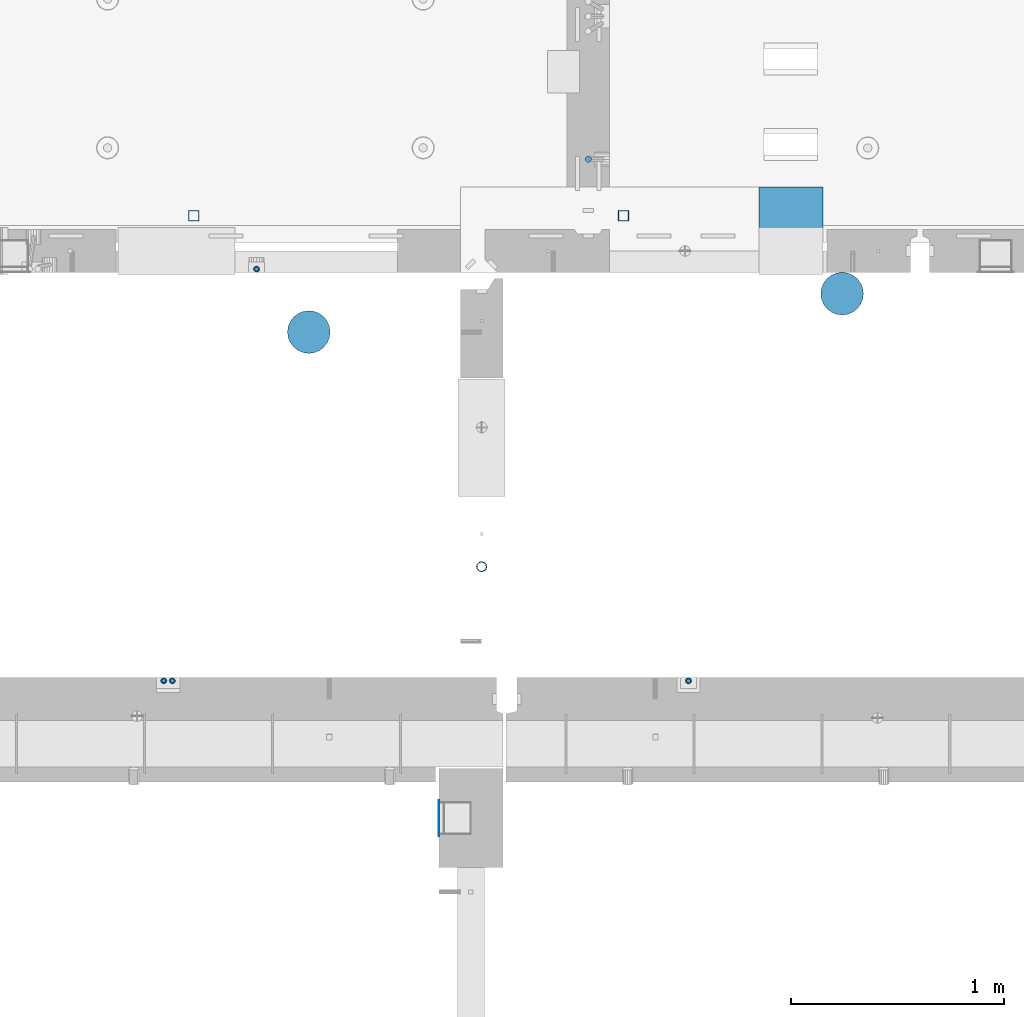
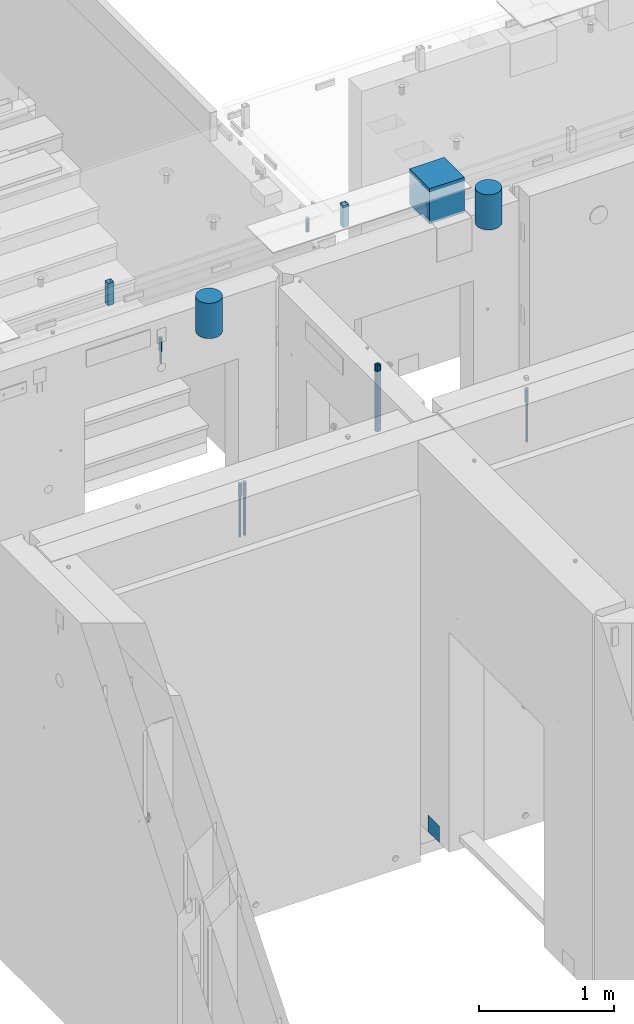
# One storey, part 9 of 264: 16 columns, 14 elements without a shape of their own.
"""IFC2X3 building model written with IfcOpenShell, lengths in millimetres."""

from ifc_helpers import new_model, si_unit, frame, origin_with_axes, place, context, subcontext, project, spatial, faceted_brep, material, type_object, element, aggregate, save


model = new_model("IFC2X3")

# Units and contexts
model_context = context("Model", 3, precision=1e-05, world=origin_with_axes())
body_context = subcontext(model_context, "Body", "Model", "MODEL_VIEW")
ifc_project = project(units=[si_unit("LENGTHUNIT", "METRE", prefix="MILLI"), si_unit("AREAUNIT", "SQUARE_METRE"), si_unit("VOLUMEUNIT", "CUBIC_METRE"), si_unit("MASSUNIT", "GRAM", prefix="KILO"), si_unit("TIMEUNIT", "SECOND"), si_unit("PLANEANGLEUNIT", "RADIAN"), si_unit("SOLIDANGLEUNIT", "STERADIAN"), si_unit("THERMODYNAMICTEMPERATUREUNIT", "DEGREE_CELSIUS"), si_unit("LUMINOUSINTENSITYUNIT", "LUMEN")], contexts=[model_context])

# Site, building, storey
site_placement = place(None, origin_with_axes())
site = spatial("IfcSite", under=ifc_project, at=site_placement, CompositionType="ELEMENT")
building_placement = place(site_placement, origin_with_axes())
building = spatial("IfcBuilding", under=site, at=building_placement, CompositionType="ELEMENT")
storey_placement = place(building_placement, origin_with_axes())
storey = spatial("IfcBuildingStorey", under=building, at=storey_placement, Name="K", CompositionType="ELEMENT", Elevation=0.0)

# Assembly, column
assembly_1_placement = place(storey_placement, origin_with_axes())
assembly_1 = element("IfcElementAssembly", 1, at=assembly_1_placement, inside=storey, AssemblyPlace="NOTDEFINED", PredefinedType="REINFORCEMENT_UNIT")
ifc_material_1 = material()
column_type_1 = type_object("IfcColumnType", Name="D30", PredefinedType="NOTDEFINED")
column_1_placement = place(assembly_1_placement, frame((22310.0, 15610.002446039, 81395.0), z_axis=(-1.0, 3.00000001838171e-08, 0.0), x_axis=(0.0, 0.0, 1.0)))
column_1 = element("IfcColumn", 2, at=column_1_placement, type_object=column_type_1, material=ifc_material_1, ObjectType="D30", context=body_context, shape_type="Brep", body=[
    faceted_brep([(0.0, -15.0, 0.0), (0.0, -12.9903810567666, -7.5), (125.0, -12.9903810567666, -7.5), (125.0, -15.0, 0.0), (0.0, -7.5, -12.9903810567666), (125.0, -7.5, -12.9903810567666), (0.0, 0.0, -15.0), (125.0, 0.0, -15.0), (0.0, 7.5, -12.9903810567666), (125.0, 7.5, -12.9903810567666), (0.0, 12.9903810567666, -7.5), (125.0, 12.9903810567666, -7.5), (0.0, 15.0, 0.0), (125.0, 15.0, 0.0), (0.0, 12.9903810567666, 7.5), (125.0, 12.9903810567666, 7.5), (0.0, 7.5, 12.9903810567666), (125.0, 7.5, 12.9903810567666), (0.0, 0.0, 15.0), (125.0, 0.0, 15.0), (0.0, -7.5, 12.9903810567666), (125.0, -7.5, 12.9903810567666), (0.0, -12.9903810567666, 7.5), (125.0, -12.9903810567666, 7.5)], [[[0, 1, 2, 3]], [[1, 4, 5, 2]], [[4, 6, 7, 5]], [[6, 8, 9, 7]], [[8, 10, 11, 9]], [[10, 12, 13, 11]], [[12, 14, 15, 13]], [[14, 16, 17, 15]], [[16, 18, 19, 17]], [[18, 20, 21, 19]], [[20, 22, 23, 21]], [[22, 0, 3, 23]], [[5, 7, 9, 11, 13, 15, 17, 19, 21, 23, 3, 2]], [[22, 20, 18, 16, 14, 12, 10, 8, 6, 4, 1, 0]]]),
])
aggregate(assembly_1, [column_1])

assembly_2_placement = place(storey_placement, origin_with_axes())
assembly_2 = element("IfcElementAssembly", 3, at=assembly_2_placement, inside=storey, AssemblyPlace="NOTDEFINED", PredefinedType="REINFORCEMENT_UNIT")
column_2_placement = place(assembly_2_placement, frame((20320.0008657669, 13165.0018965848, 81167.5), z_axis=(0.0, -1.0, 0.0), x_axis=(0.0, 0.0, 1.0)))
column_2 = element("IfcColumn", 4, at=column_2_placement, type_object=column_type_1, material=ifc_material_1, ObjectType="D30", context=body_context, shape_type="Brep", body=[
    faceted_brep([(0.0, -15.0, 0.0), (0.0, -12.9903810567666, -7.5), (125.0, -12.9903810567666, -7.5), (125.0, -15.0, 0.0), (0.0, -7.5, -12.9903810567666), (125.0, -7.5, -12.9903810567666), (0.0, 0.0, -15.0), (125.0, 0.0, -15.0), (0.0, 7.5, -12.9903810567666), (125.0, 7.5, -12.9903810567666), (0.0, 12.9903810567666, -7.5), (125.0, 12.9903810567666, -7.5), (0.0, 15.0, 0.0), (125.0, 15.0, 0.0), (0.0, 12.9903810567666, 7.5), (125.0, 12.9903810567666, 7.5), (0.0, 7.5, 12.9903810567666), (125.0, 7.5, 12.9903810567666), (0.0, 0.0, 15.0), (125.0, 0.0, 15.0), (0.0, -7.5, 12.9903810567666), (125.0, -7.5, 12.9903810567666), (0.0, -12.9903810567666, 7.5), (125.0, -12.9903810567666, 7.5)], [[[0, 1, 2, 3]], [[1, 4, 5, 2]], [[4, 6, 7, 5]], [[6, 8, 9, 7]], [[8, 10, 11, 9]], [[10, 12, 13, 11]], [[12, 14, 15, 13]], [[14, 16, 17, 15]], [[16, 18, 19, 17]], [[18, 20, 21, 19]], [[20, 22, 23, 21]], [[22, 0, 3, 23]], [[5, 7, 9, 11, 13, 15, 17, 19, 21, 23, 3, 2]], [[22, 20, 18, 16, 14, 12, 10, 8, 6, 4, 1, 0]]]),
])

assembly_3_placement = place(storey_placement, origin_with_axes())
assembly_3 = element("IfcElementAssembly", 5, at=assembly_3_placement, inside=storey, AssemblyPlace="NOTDEFINED", PredefinedType="REINFORCEMENT_UNIT")
column_3_placement = place(assembly_3_placement, frame((22780.0008657669, 13165.0018965848, 81167.5), z_axis=(0.0, -1.0, 0.0), x_axis=(0.0, 0.0, 1.0)))
column_3 = element("IfcColumn", 6, at=column_3_placement, type_object=column_type_1, material=ifc_material_1, ObjectType="D30", context=body_context, shape_type="Brep", body=[
    faceted_brep([(0.0, -15.0, 0.0), (0.0, -12.9903810567666, -7.5), (125.0, -12.9903810567666, -7.5), (125.0, -15.0, 0.0), (0.0, -7.5, -12.9903810567666), (125.0, -7.5, -12.9903810567666), (0.0, 0.0, -15.0), (125.0, 0.0, -15.0), (0.0, 7.5, -12.9903810567666), (125.0, 7.5, -12.9903810567666), (0.0, 12.9903810567666, -7.5), (125.0, 12.9903810567666, -7.5), (0.0, 15.0, 0.0), (125.0, 15.0, 0.0), (0.0, 12.9903810567666, 7.5), (125.0, 12.9903810567666, 7.5), (0.0, 7.5, 12.9903810567666), (125.0, 7.5, 12.9903810567666), (0.0, 0.0, 15.0), (125.0, 0.0, 15.0), (0.0, -7.5, 12.9903810567666), (125.0, -7.5, 12.9903810567666), (0.0, -12.9903810567666, 7.5), (125.0, -12.9903810567666, 7.5)], [[[0, 1, 2, 3]], [[1, 4, 5, 2]], [[4, 6, 7, 5]], [[6, 8, 9, 7]], [[8, 10, 11, 9]], [[10, 12, 13, 11]], [[12, 14, 15, 13]], [[14, 16, 17, 15]], [[16, 18, 19, 17]], [[18, 20, 21, 19]], [[20, 22, 23, 21]], [[22, 0, 3, 23]], [[5, 7, 9, 11, 13, 15, 17, 19, 21, 23, 3, 2]], [[22, 20, 18, 16, 14, 12, 10, 8, 6, 4, 1, 0]]]),
])

# Column
column_4_placement = place(assembly_2_placement, frame((20360.0008657669, 13165.0018965848, 81167.5), z_axis=(0.0, -1.0, 0.0), x_axis=(0.0, 0.0, 1.0)))
column_4 = element("IfcColumn", 7, at=column_4_placement, type_object=column_type_1, material=ifc_material_1, ObjectType="D30", context=body_context, shape_type="Brep", body=[
    faceted_brep([(0.0, -15.0, 0.0), (0.0, -12.9903810567666, -7.5), (125.0, -12.9903810567666, -7.5), (125.0, -15.0, 0.0), (0.0, -7.5, -12.9903810567666), (125.0, -7.5, -12.9903810567666), (0.0, 0.0, -15.0), (125.0, 0.0, -15.0), (0.0, 7.5, -12.9903810567666), (125.0, 7.5, -12.9903810567666), (0.0, 12.9903810567666, -7.5), (125.0, 12.9903810567666, -7.5), (0.0, 15.0, 0.0), (125.0, 15.0, 0.0), (0.0, 12.9903810567666, 7.5), (125.0, 12.9903810567666, 7.5), (0.0, 7.5, 12.9903810567666), (125.0, 7.5, 12.9903810567666), (0.0, 0.0, 15.0), (125.0, 0.0, 15.0), (0.0, -7.5, 12.9903810567666), (125.0, -7.5, 12.9903810567666), (0.0, -12.9903810567666, 7.5), (125.0, -12.9903810567666, 7.5)], [[[0, 1, 2, 3]], [[1, 4, 5, 2]], [[4, 6, 7, 5]], [[6, 8, 9, 7]], [[8, 10, 11, 9]], [[10, 12, 13, 11]], [[12, 14, 15, 13]], [[14, 16, 17, 15]], [[16, 18, 19, 17]], [[18, 20, 21, 19]], [[20, 22, 23, 21]], [[22, 0, 3, 23]], [[5, 7, 9, 11, 13, 15, 17, 19, 21, 23, 3, 2]], [[22, 20, 18, 16, 14, 12, 10, 8, 6, 4, 1, 0]]]),
])

# Assembly, column
assembly_4_placement = place(storey_placement, origin_with_axes())
assembly_4 = element("IfcElementAssembly", 8, at=assembly_4_placement, inside=storey, AssemblyPlace="NOTDEFINED", PredefinedType="REINFORCEMENT_UNIT")
column_5_placement = place(assembly_4_placement, frame((20755.0015915468, 15095.0, 81167.5), z_axis=(0.0, 1.0, 0.0), x_axis=(0.0, 0.0, 1.0)))
column_5 = element("IfcColumn", 9, at=column_5_placement, type_object=column_type_1, material=ifc_material_1, ObjectType="D30", context=body_context, shape_type="Brep", body=[
    faceted_brep([(0.0, -15.0, 0.0), (0.0, -12.9903810567666, -7.5), (125.0, -12.9903810567666, -7.5), (125.0, -15.0, 0.0), (0.0, -7.5, -12.9903810567666), (125.0, -7.5, -12.9903810567666), (0.0, 0.0, -15.0), (125.0, 0.0, -15.0), (0.0, 7.5, -12.9903810567666), (125.0, 7.5, -12.9903810567666), (0.0, 12.9903810567666, -7.5), (125.0, 12.9903810567666, -7.5), (0.0, 15.0, 0.0), (125.0, 15.0, 0.0), (0.0, 12.9903810567666, 7.5), (125.0, 12.9903810567666, 7.5), (0.0, 7.5, 12.9903810567666), (125.0, 7.5, 12.9903810567666), (0.0, 0.0, 15.0), (125.0, 0.0, 15.0), (0.0, -7.5, 12.9903810567666), (125.0, -7.5, 12.9903810567666), (0.0, -12.9903810567666, 7.5), (125.0, -12.9903810567666, 7.5)], [[[0, 1, 2, 3]], [[1, 4, 5, 2]], [[4, 6, 7, 5]], [[6, 8, 9, 7]], [[8, 10, 11, 9]], [[10, 12, 13, 11]], [[12, 14, 15, 13]], [[14, 16, 17, 15]], [[16, 18, 19, 17]], [[18, 20, 21, 19]], [[20, 22, 23, 21]], [[22, 0, 3, 23]], [[5, 7, 9, 11, 13, 15, 17, 19, 21, 23, 3, 2]], [[22, 20, 18, 16, 14, 12, 10, 8, 6, 4, 1, 0]]]),
])

# Assemblies, column
assembly_5_placement = place(storey_placement, origin_with_axes())
assembly_5 = element("IfcElementAssembly", 10, at=assembly_5_placement, inside=storey, AssemblyPlace="NOTDEFINED", PredefinedType="REINFORCEMENT_UNIT")
assembly_6_placement = place(assembly_5_placement, origin_with_axes())
assembly_6 = element("IfcElementAssembly", 11, at=assembly_6_placement, Name="Steel Assembly", AssemblyPlace="NOTDEFINED", PredefinedType="NOTDEFINED")
aggregate(assembly_5, [assembly_6])
ifc_material_2 = material(Name="Undefined")
column_type_2 = type_object("IfcColumnType", PredefinedType="NOTDEFINED")
column_6_placement = place(assembly_6_placement, frame((21610.9999999634, 12520.5, 78020.0000050936), z_axis=(-1.0, 3.00000001838171e-08, 0.0), x_axis=(0.0, 0.0, 1.0)))
column_6 = element("IfcColumn", 12, at=column_6_placement, type_object=column_type_2, material=ifc_material_2, Name="SPK3", context=body_context, shape_type="Brep", body=[
    faceted_brep([(0.0, 85.0, -1.0), (0.0, 85.0, 1.0), (150.0, 85.0, 1.0), (150.0, 85.0, -1.0), (0.0, -85.0, 1.0), (150.0, -85.0, 1.0), (0.0, -85.0, -1.0), (150.0, -85.0, -1.0)], [[[0, 1, 2, 3]], [[1, 4, 5, 2]], [[4, 6, 7, 5]], [[6, 0, 3, 7]], [[5, 7, 3, 2]], [[6, 4, 1, 0]]]),
])
aggregate(assembly_6, [column_6])

assembly_7_placement = place(storey_placement, origin_with_axes())
assembly_7 = element("IfcElementAssembly", 13, at=assembly_7_placement, inside=storey, AssemblyPlace="NOTDEFINED", PredefinedType="REINFORCEMENT_UNIT")
assembly_8_placement = place(assembly_7_placement, origin_with_axes())
assembly_8 = element("IfcElementAssembly", 14, at=assembly_8_placement, Name="Steel Assembly", AssemblyPlace="NOTDEFINED", PredefinedType="RIGID_FRAME")
aggregate(assembly_7, [assembly_8])
ifc_material_3 = material(Name="STEEL/S355J2")
column_type_3 = type_object("IfcColumnType", Name="50X50X3", PredefinedType="NOTDEFINED")
column_7_placement = place(assembly_8_placement, frame((20460.0059390845, 15345.0026483099, 81550.0), z_axis=(-1.0, 3.00000001838171e-08, 0.0), x_axis=(0.0, 0.0, 1.0)))
column_7 = element("IfcColumn", 15, at=column_7_placement, type_object=column_type_3, material=ifc_material_3, ObjectType="50X50X3", context=body_context, shape_type="Brep", body=[
    faceted_brep([(0.0, 22.0, -22.0), (0.0, -22.0, -22.0), (200.0, -22.0, -22.0), (200.0, 22.0, -22.0), (0.0, -22.0, 22.0), (200.0, -22.0, 22.0), (0.0, 22.0, 22.0), (200.0, 22.0, 22.0), (0.0, 25.0, -25.0), (0.0, 25.0, 25.0), (200.0, 25.0, 25.0), (200.0, 25.0, -25.0), (0.0, -25.0, 25.0), (200.0, -25.0, 25.0), (0.0, -25.0, -25.0), (200.0, -25.0, -25.0)], [[[0, 1, 2, 3]], [[1, 4, 5, 2]], [[4, 6, 7, 5]], [[6, 0, 3, 7]], [[8, 9, 10, 11]], [[9, 12, 13, 10]], [[12, 14, 15, 13]], [[14, 8, 11, 15]], [[13, 15, 11, 10], [5, 7, 3, 2]], [[14, 12, 9, 8], [6, 4, 1, 0]]]),
])
aggregate(assembly_8, [column_7])

assembly_9_placement = place(storey_placement, origin_with_axes())
assembly_9 = element("IfcElementAssembly", 16, at=assembly_9_placement, inside=storey, AssemblyPlace="NOTDEFINED", PredefinedType="REINFORCEMENT_UNIT")
assembly_10_placement = place(assembly_9_placement, origin_with_axes())
assembly_10 = element("IfcElementAssembly", 17, at=assembly_10_placement, Name="Steel Assembly", AssemblyPlace="NOTDEFINED", PredefinedType="RIGID_FRAME")
aggregate(assembly_9, [assembly_10])
column_8_placement = place(assembly_10_placement, frame((22475.0059390845, 15345.0026483099, 81550.0), z_axis=(-1.0, 3.00000001838171e-08, 0.0), x_axis=(0.0, 0.0, 1.0)))
column_8 = element("IfcColumn", 18, at=column_8_placement, type_object=column_type_3, material=ifc_material_3, ObjectType="50X50X3", context=body_context, shape_type="Brep", body=[
    faceted_brep([(0.0, 22.0, -22.0), (0.0, -22.0, -22.0), (200.0, -22.0, -22.0), (200.0, 22.0, -22.0), (0.0, -22.0, 22.0), (200.0, -22.0, 22.0), (0.0, 22.0, 22.0), (200.0, 22.0, 22.0), (0.0, 25.0, -25.0), (0.0, 25.0, 25.0), (200.0, 25.0, 25.0), (200.0, 25.0, -25.0), (0.0, -25.0, 25.0), (200.0, -25.0, 25.0), (0.0, -25.0, -25.0), (200.0, -25.0, -25.0)], [[[0, 1, 2, 3]], [[1, 4, 5, 2]], [[4, 6, 7, 5]], [[6, 0, 3, 7]], [[8, 9, 10, 11]], [[9, 12, 13, 10]], [[12, 14, 15, 13]], [[14, 8, 11, 15]], [[13, 15, 11, 10], [5, 7, 3, 2]], [[14, 12, 9, 8], [6, 4, 1, 0]]]),
])
aggregate(assembly_10, [column_8])

# Assembly, column
assembly_11_placement = place(storey_placement, origin_with_axes())
assembly_11 = element("IfcElementAssembly", 19, at=assembly_11_placement, inside=storey, AssemblyPlace="NOTDEFINED", PredefinedType="REINFORCEMENT_UNIT")
ifc_material_4 = material()
column_type_4 = type_object("IfcColumnType", Name="48.3X2.6", PredefinedType="NOTDEFINED")
column_9_placement = place(assembly_11_placement, frame((21809.9991042544, 13700.0, 80925.0), z_axis=(-1.0, 3.00000001838171e-08, 0.0), x_axis=(0.0, 0.0, 1.0)))
column_9 = element("IfcColumn", 20, at=column_9_placement, type_object=column_type_4, material=ifc_material_4, ObjectType="48.3X2.6", context=body_context, shape_type="Brep", body=[
    faceted_brep([(0.0, -21.5499999999993, 0.0), (0.0, -18.6628474515564, 10.7750000000015), (595.0, -18.6628474515546, 10.7750000000015), (595.0, -21.5499999999993, 0.0), (0.0, -10.7750000000015, 18.6628474515564), (595.0, -10.7749999999996, 18.6628474515564), (0.0, 0.0, 21.5499999999993), (595.0, 0.0, 21.5499999999993), (0.0, 10.7750000000015, 18.6628474515564), (595.0, 10.7749999999996, 18.6628474515564), (0.0, 18.6628474515564, 10.7750000000015), (595.0, 18.6628474515546, 10.7750000000015), (0.0, 21.5499999999993, 0.0), (595.0, 21.5499999999993, 0.0), (0.0, 18.6628474515564, -10.7750000000015), (595.0, 18.6628474515546, -10.7750000000015), (0.0, 10.7750000000015, -18.6628474515564), (595.0, 10.7749999999996, -18.6628474515564), (0.0, 0.0, -21.5499999999993), (595.0, 0.0, -21.5499999999993), (0.0, -10.7750000000015, -18.6628474515564), (595.0, -10.7749999999996, -18.6628474515564), (0.0, -18.6628474515564, -10.7750000000015), (595.0, -18.6628474515546, -10.7750000000015), (0.0, -24.1500000000015, 0.0), (0.0, -20.9145135013932, -12.0750000000007), (595.0, -20.914513501395, -12.0750000000007), (595.0, -24.1499999999996, 0.0), (0.0, -12.0750000000007, -20.9145135013932), (595.0, -12.0750000000007, -20.9145135013932), (0.0, 0.0, -24.1500000000015), (595.0, 0.0, -24.1500000000015), (0.0, 12.0750000000007, -20.9145135013932), (595.0, 12.0750000000007, -20.9145135013932), (0.0, 20.9145135013932, -12.0750000000007), (595.0, 20.914513501395, -12.0750000000007), (0.0, 24.1500000000015, 0.0), (595.0, 24.1499999999996, 0.0), (0.0, 20.9145135013932, 12.0750000000007), (595.0, 20.914513501395, 12.0750000000007), (0.0, 12.0750000000007, 20.9145135013932), (595.0, 12.0750000000007, 20.9145135013932), (0.0, 0.0, 24.1500000000015), (595.0, 0.0, 24.1500000000015), (0.0, -12.0750000000007, 20.9145135013932), (595.0, -12.0750000000007, 20.9145135013932), (0.0, -20.9145135013932, 12.0750000000007), (595.0, -20.914513501395, 12.0750000000007)], [[[0, 1, 2, 3]], [[1, 4, 5, 2]], [[4, 6, 7, 5]], [[6, 8, 9, 7]], [[8, 10, 11, 9]], [[10, 12, 13, 11]], [[12, 14, 15, 13]], [[14, 16, 17, 15]], [[16, 18, 19, 17]], [[18, 20, 21, 19]], [[20, 22, 23, 21]], [[22, 0, 3, 23]], [[24, 25, 26, 27]], [[25, 28, 29, 26]], [[28, 30, 31, 29]], [[30, 32, 33, 31]], [[32, 34, 35, 33]], [[34, 36, 37, 35]], [[36, 38, 39, 37]], [[38, 40, 41, 39]], [[40, 42, 43, 41]], [[42, 44, 45, 43]], [[44, 46, 47, 45]], [[46, 24, 27, 47]], [[29, 31, 33, 35, 37, 39, 41, 43, 45, 47, 27, 26], [5, 7, 9, 11, 13, 15, 17, 19, 21, 23, 3, 2]], [[46, 44, 42, 40, 38, 36, 34, 32, 30, 28, 25, 24], [22, 20, 18, 16, 14, 12, 10, 8, 6, 4, 1, 0]]]),
])
aggregate(assembly_11, [column_9])

# Column
column_type_5 = type_object("IfcColumnType", Name="D20", PredefinedType="NOTDEFINED")
column_10_placement = place(assembly_3_placement, frame((22780.0008657664, 13165.0018965848, 80805.0), z_axis=(0.0, -1.0, 0.0), x_axis=(0.0, 0.0, 1.0)))
column_10 = element("IfcColumn", 21, at=column_10_placement, type_object=column_type_5, material=ifc_material_1, Name="JM20", ObjectType="D20", context=body_context, shape_type="Brep", body=[
    faceted_brep([(0.0, -10.0, 0.0), (-4.19531716033816e-08, -7.07106781186667, -7.07106781187031), (362.5, -7.07106781186667, -7.07106781186485), (362.5, -10.0, 0.0), (0.0, 0.0, -10.0), (362.5, 0.0, -10.0), (4.196772351861e-08, 7.07106781186303, -7.07106781186667), (362.5, 7.07106781186667, -7.07106781186485), (0.0, 10.0, 0.0), (362.5, 10.0, 0.0), (4.196772351861e-08, 7.07106781185939, 7.07106781185939), (362.5, 7.07106781186667, 7.07106781186485), (0.0, 0.0, 10.0), (362.5, 0.0, 10.0), (-4.19531716033816e-08, -7.07106781187031, 7.07106781185939), (362.5, -7.07106781186667, 7.07106781186485)], [[[0, 1, 2, 3]], [[1, 4, 5, 2]], [[4, 6, 7, 5]], [[6, 8, 9, 7]], [[8, 10, 11, 9]], [[10, 12, 13, 11]], [[12, 14, 15, 13]], [[14, 0, 3, 15]], [[5, 7, 9, 11, 13, 15, 3, 2]], [[14, 12, 10, 8, 6, 4, 1, 0]]]),
])

aggregate(assembly_3, [column_10, column_3])

column_11_placement = place(assembly_2_placement, frame((20320.0008657664, 13165.0018965848, 80805.0), z_axis=(0.0, -1.0, 0.0), x_axis=(0.0, 0.0, 1.0)))
column_11 = element("IfcColumn", 22, at=column_11_placement, type_object=column_type_5, material=ifc_material_1, Name="JM20", ObjectType="D20", context=body_context, shape_type="Brep", body=[
    faceted_brep([(0.0, -10.0, 0.0), (-4.19531716033816e-08, -7.07106781186667, -7.07106781187031), (362.5, -7.07106781186667, -7.07106781186485), (362.5, -10.0, 0.0), (0.0, 0.0, -10.0), (362.5, 0.0, -10.0), (4.196772351861e-08, 7.07106781186303, -7.07106781186667), (362.5, 7.07106781186667, -7.07106781186485), (0.0, 10.0, 0.0), (362.5, 10.0, 0.0), (4.196772351861e-08, 7.07106781185939, 7.07106781185939), (362.5, 7.07106781186667, 7.07106781186485), (0.0, 0.0, 10.0), (362.5, 0.0, 10.0), (-4.19531716033816e-08, -7.07106781187031, 7.07106781185939), (362.5, -7.07106781186667, 7.07106781186485)], [[[0, 1, 2, 3]], [[1, 4, 5, 2]], [[4, 6, 7, 5]], [[6, 8, 9, 7]], [[8, 10, 11, 9]], [[10, 12, 13, 11]], [[12, 14, 15, 13]], [[14, 0, 3, 15]], [[5, 7, 9, 11, 13, 15, 3, 2]], [[14, 12, 10, 8, 6, 4, 1, 0]]]),
])

column_12_placement = place(assembly_2_placement, frame((20360.0008657664, 13165.0018965848, 80805.0), z_axis=(0.0, -1.0, 0.0), x_axis=(0.0, 0.0, 1.0)))
column_12 = element("IfcColumn", 23, at=column_12_placement, type_object=column_type_5, material=ifc_material_1, Name="JM20", ObjectType="D20", context=body_context, shape_type="Brep", body=[
    faceted_brep([(0.0, -10.0, 0.0), (-4.19531716033816e-08, -7.07106781186667, -7.07106781187031), (362.5, -7.07106781186667, -7.07106781186485), (362.5, -10.0, 0.0), (0.0, 0.0, -10.0), (362.5, 0.0, -10.0), (4.196772351861e-08, 7.07106781186303, -7.07106781186667), (362.5, 7.07106781186667, -7.07106781186485), (0.0, 10.0, 0.0), (362.5, 10.0, 0.0), (4.196772351861e-08, 7.07106781185939, 7.07106781185939), (362.5, 7.07106781186667, 7.07106781186485), (0.0, 0.0, 10.0), (362.5, 0.0, 10.0), (-4.19531716033816e-08, -7.07106781187031, 7.07106781185939), (362.5, -7.07106781186667, 7.07106781186485)], [[[0, 1, 2, 3]], [[1, 4, 5, 2]], [[4, 6, 7, 5]], [[6, 8, 9, 7]], [[8, 10, 11, 9]], [[10, 12, 13, 11]], [[12, 14, 15, 13]], [[14, 0, 3, 15]], [[5, 7, 9, 11, 13, 15, 3, 2]], [[14, 12, 10, 8, 6, 4, 1, 0]]]),
])

aggregate(assembly_2, [column_2, column_11, column_12, column_4])

column_13_placement = place(assembly_4_placement, frame((20755.0015915473, 15095.0, 81060.0), z_axis=(0.0, 1.0, 0.0), x_axis=(0.0, 0.0, 1.0)))
column_13 = element("IfcColumn", 24, at=column_13_placement, type_object=column_type_5, material=ifc_material_1, Name="JM20", ObjectType="D20", context=body_context, shape_type="Brep", body=[
    faceted_brep([(0.0, -10.0, 0.0), (-4.19531716033816e-08, -7.07106781186667, -7.07106781187031), (107.499999999141, -7.07106781186667, -7.07106781186485), (107.499999999141, -10.0, 0.0), (0.0, 0.0, -10.0), (107.499999999141, 0.0, -10.0), (4.196772351861e-08, 7.07106781186303, -7.07106781186667), (107.499999999141, 7.07106781186667, -7.07106781186485), (0.0, 10.0, 0.0), (107.499999999141, 10.0, 0.0), (4.196772351861e-08, 7.07106781185939, 7.07106781185939), (107.499999999141, 7.07106781186667, 7.07106781186485), (0.0, 0.0, 10.0), (107.499999999141, 0.0, 10.0), (-4.19531716033816e-08, -7.07106781187031, 7.07106781185939), (107.499999999141, -7.07106781186667, 7.07106781186485)], [[[0, 1, 2, 3]], [[1, 4, 5, 2]], [[4, 6, 7, 5]], [[6, 8, 9, 7]], [[8, 10, 11, 9]], [[10, 12, 13, 11]], [[12, 14, 15, 13]], [[14, 0, 3, 15]], [[5, 7, 9, 11, 13, 15, 3, 2]], [[14, 12, 10, 8, 6, 4, 1, 0]]]),
])

aggregate(assembly_4, [column_13, column_5])

# Assembly, column
assembly_12_placement = place(storey_placement, origin_with_axes())
assembly_12 = element("IfcElementAssembly", 25, at=assembly_12_placement, inside=storey, Name="Steel Assembly", AssemblyPlace="NOTDEFINED", PredefinedType="NOTDEFINED")
ifc_material_5 = material()
column_type_6 = type_object("IfcColumnType", Name="D200", PredefinedType="NOTDEFINED")
column_14_placement = place(assembly_12_placement, frame((23500.0177759084, 14980.002162212, 81440.0), z_axis=(0.0, 1.0, 0.0), x_axis=(0.0, 0.0, 1.0)))
column_14 = element("IfcColumn", 26, at=column_14_placement, type_object=column_type_6, material=ifc_material_5, ObjectType="D200", context=body_context, shape_type="Brep", body=[
    faceted_brep([(0.0, -100.0, 0.0), (0.0, -96.5925826289022, -25.8819045102518), (320.0, -96.5925826289058, -25.8819045102518), (320.0, -100.0, 0.0), (0.0, -86.6025403784442, -50.0), (320.0, -86.6025403784442, -50.0), (0.0, -70.7106781186594, -70.710678118654), (320.0, -70.7106781186558, -70.710678118654), (0.0, -50.0, -86.6025403784442), (320.0, -50.0, -86.6025403784442), (0.0, -25.8819045102573, -96.5925826289076), (320.0, -25.8819045102537, -96.5925826289076), (0.0, 0.0, -100.0), (320.0, 0.0, -100.0), (0.0, 25.8819045102573, -96.5925826289076), (320.0, 25.8819045102537, -96.5925826289076), (0.0, 50.0, -86.6025403784442), (320.0, 50.0, -86.6025403784442), (0.0, 70.7106781186594, -70.710678118654), (320.0, 70.7106781186558, -70.710678118654), (0.0, 86.6025403784442, -50.0), (320.0, 86.6025403784442, -50.0), (0.0, 96.5925826289022, -25.8819045102518), (320.0, 96.5925826289058, -25.8819045102518), (0.0, 100.0, 0.0), (320.0, 100.0, 0.0), (0.0, 96.5925826289022, 25.8819045102518), (320.0, 96.5925826289058, 25.8819045102518), (0.0, 86.6025403784442, 50.0), (320.0, 86.6025403784442, 50.0), (0.0, 70.7106781186594, 70.710678118654), (320.0, 70.7106781186558, 70.710678118654), (0.0, 50.0, 86.6025403784442), (320.0, 50.0, 86.6025403784442), (0.0, 25.8819045102573, 96.5925826289076), (320.0, 25.8819045102537, 96.5925826289076), (0.0, 0.0, 100.0), (320.0, 0.0, 100.0), (0.0, -25.8819045102573, 96.5925826289076), (320.0, -25.8819045102537, 96.5925826289076), (0.0, -50.0, 86.6025403784442), (320.0, -50.0, 86.6025403784442), (0.0, -70.7106781186594, 70.710678118654), (320.0, -70.7106781186558, 70.710678118654), (0.0, -86.6025403784442, 50.0), (320.0, -86.6025403784442, 50.0), (0.0, -96.5925826289022, 25.8819045102518), (320.0, -96.5925826289058, 25.8819045102518)], [[[0, 1, 2, 3]], [[1, 4, 5, 2]], [[4, 6, 7, 5]], [[6, 8, 9, 7]], [[8, 10, 11, 9]], [[10, 12, 13, 11]], [[12, 14, 15, 13]], [[14, 16, 17, 15]], [[16, 18, 19, 17]], [[18, 20, 21, 19]], [[20, 22, 23, 21]], [[22, 24, 25, 23]], [[24, 26, 27, 25]], [[26, 28, 29, 27]], [[28, 30, 31, 29]], [[30, 32, 33, 31]], [[32, 34, 35, 33]], [[34, 36, 37, 35]], [[36, 38, 39, 37]], [[38, 40, 41, 39]], [[40, 42, 43, 41]], [[42, 44, 45, 43]], [[44, 46, 47, 45]], [[46, 0, 3, 47]], [[5, 7, 9, 11, 13, 15, 17, 19, 21, 23, 25, 27, 29, 31, 33, 35, 37, 39, 41, 43, 45, 47, 3, 2]], [[46, 44, 42, 40, 38, 36, 34, 32, 30, 28, 26, 24, 22, 20, 18, 16, 14, 12, 10, 8, 6, 4, 1, 0]]]),
])
aggregate(assembly_12, [column_14])

assembly_13_placement = place(storey_placement, origin_with_axes())
assembly_13 = element("IfcElementAssembly", 27, at=assembly_13_placement, inside=storey, Name="Steel Assembly", AssemblyPlace="NOTDEFINED", PredefinedType="NOTDEFINED")
column_15_placement = place(assembly_13_placement, frame((21000.0007614493, 14800.0003799796, 81440.0), z_axis=(0.0, 1.0, 0.0), x_axis=(0.0, 0.0, 1.0)))
column_15 = element("IfcColumn", 28, at=column_15_placement, type_object=column_type_6, material=ifc_material_5, ObjectType="D200", context=body_context, shape_type="Brep", body=[
    faceted_brep([(0.0, -100.0, 0.0), (0.0, -96.5925826289022, -25.8819045102518), (320.0, -96.5925826289058, -25.8819045102518), (320.0, -100.0, 0.0), (0.0, -86.6025403784442, -50.0), (320.0, -86.6025403784442, -50.0), (0.0, -70.7106781186594, -70.710678118654), (320.0, -70.7106781186558, -70.710678118654), (0.0, -50.0, -86.6025403784442), (320.0, -50.0, -86.6025403784442), (0.0, -25.8819045102573, -96.5925826289076), (320.0, -25.8819045102537, -96.5925826289076), (0.0, 0.0, -100.0), (320.0, 0.0, -100.0), (0.0, 25.8819045102573, -96.5925826289076), (320.0, 25.8819045102537, -96.5925826289076), (0.0, 50.0, -86.6025403784442), (320.0, 50.0, -86.6025403784442), (0.0, 70.7106781186594, -70.710678118654), (320.0, 70.7106781186558, -70.710678118654), (0.0, 86.6025403784442, -50.0), (320.0, 86.6025403784442, -50.0), (0.0, 96.5925826289022, -25.8819045102518), (320.0, 96.5925826289058, -25.8819045102518), (0.0, 100.0, 0.0), (320.0, 100.0, 0.0), (0.0, 96.5925826289022, 25.8819045102518), (320.0, 96.5925826289058, 25.8819045102518), (0.0, 86.6025403784442, 50.0), (320.0, 86.6025403784442, 50.0), (0.0, 70.7106781186594, 70.710678118654), (320.0, 70.7106781186558, 70.710678118654), (0.0, 50.0, 86.6025403784442), (320.0, 50.0, 86.6025403784442), (0.0, 25.8819045102573, 96.5925826289076), (320.0, 25.8819045102537, 96.5925826289076), (0.0, 0.0, 100.0), (320.0, 0.0, 100.0), (0.0, -25.8819045102573, 96.5925826289076), (320.0, -25.8819045102537, 96.5925826289076), (0.0, -50.0, 86.6025403784442), (320.0, -50.0, 86.6025403784442), (0.0, -70.7106781186594, 70.710678118654), (320.0, -70.7106781186558, 70.710678118654), (0.0, -86.6025403784442, 50.0), (320.0, -86.6025403784442, 50.0), (0.0, -96.5925826289022, 25.8819045102518), (320.0, -96.5925826289058, 25.8819045102518)], [[[0, 1, 2, 3]], [[1, 4, 5, 2]], [[4, 6, 7, 5]], [[6, 8, 9, 7]], [[8, 10, 11, 9]], [[10, 12, 13, 11]], [[12, 14, 15, 13]], [[14, 16, 17, 15]], [[16, 18, 19, 17]], [[18, 20, 21, 19]], [[20, 22, 23, 21]], [[22, 24, 25, 23]], [[24, 26, 27, 25]], [[26, 28, 29, 27]], [[28, 30, 31, 29]], [[30, 32, 33, 31]], [[32, 34, 35, 33]], [[34, 36, 37, 35]], [[36, 38, 39, 37]], [[38, 40, 41, 39]], [[40, 42, 43, 41]], [[42, 44, 45, 43]], [[44, 46, 47, 45]], [[46, 0, 3, 47]], [[5, 7, 9, 11, 13, 15, 17, 19, 21, 23, 25, 27, 29, 31, 33, 35, 37, 39, 41, 43, 45, 47, 3, 2]], [[46, 44, 42, 40, 38, 36, 34, 32, 30, 28, 26, 24, 22, 20, 18, 16, 14, 12, 10, 8, 6, 4, 1, 0]]]),
])
aggregate(assembly_13, [column_15])

assembly_14_placement = place(storey_placement, origin_with_axes())
assembly_14 = element("IfcElementAssembly", 29, at=assembly_14_placement, inside=storey, Name="Steel Assembly", AssemblyPlace="NOTDEFINED", PredefinedType="NOTDEFINED")
column_type_7 = type_object("IfcColumnType", PredefinedType="NOTDEFINED")
column_16_placement = place(assembly_14_placement, frame((23259.9994644523, 15330.0003036857, 81440.0), z_axis=(0.0, 1.0, 0.0), x_axis=(0.0, 0.0, 1.0)))
column_16 = element("IfcColumn", 30, at=column_16_placement, type_object=column_type_7, material=ifc_material_5, context=body_context, shape_type="Brep", body=[
    faceted_brep([(0.0, 150.0, -150.0), (0.0, 150.0, 150.0), (320.0, 150.0, 150.0), (320.0, 150.0, -150.0), (0.0, -150.0, 150.0), (320.0, -150.0, 150.0), (0.0, -150.0, -150.0), (320.0, -150.0, -150.0)], [[[0, 1, 2, 3]], [[1, 4, 5, 2]], [[4, 6, 7, 5]], [[6, 0, 3, 7]], [[5, 7, 3, 2]], [[6, 4, 1, 0]]]),
])
aggregate(assembly_14, [column_16])

save(model, "model.ifc")
